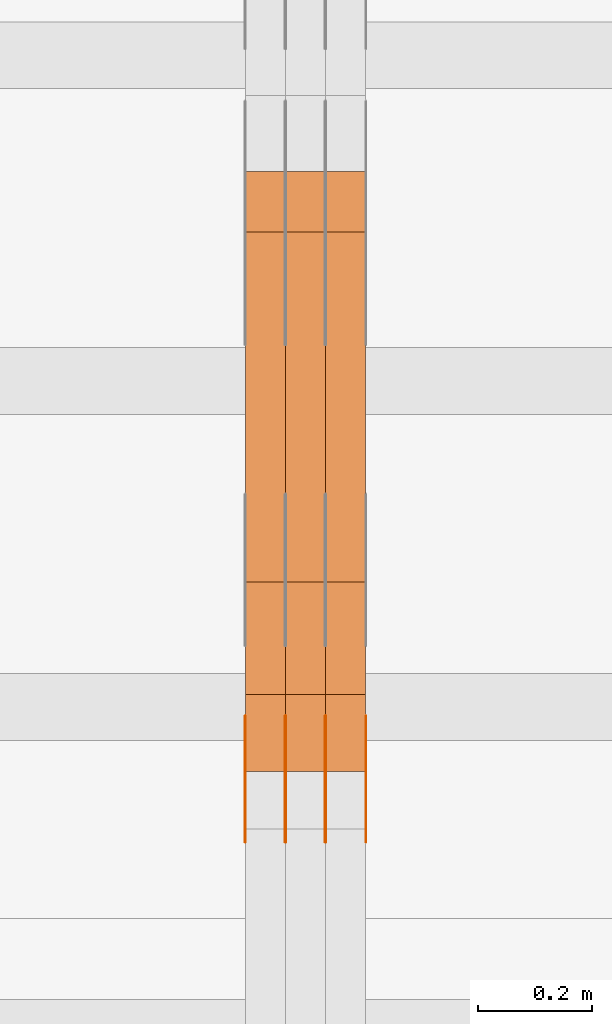
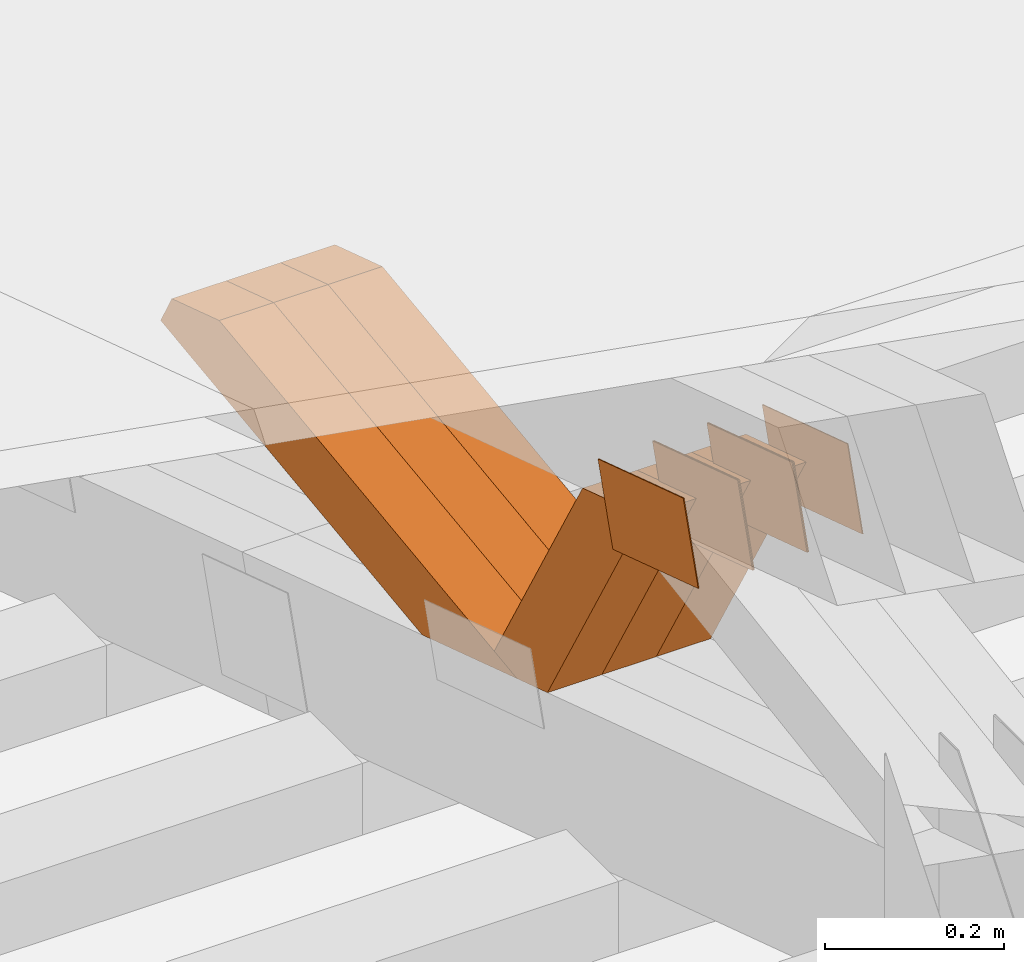
# One storey, part 107 of 385: 12 proxies.
"""IFC2X3 building model written with IfcOpenShell, lengths in millimetres."""

import ifcopenshell
import ifcopenshell.guid

model = None  # the IFC model being written
_history = None  # IfcOwnerHistory: only IFC2X3 demands one
_inside = {}  # id of a spatial element -> (the spatial element, [elements in it])
_under = {}  # id of a project, library or spatial element -> (it, [spatial elements below it])
_declared = {}  # id of a project -> (the project, [libraries it declares])
_typed = {}  # id of a type object -> (the type object, [elements of that type])
_made_of = {}  # id of a material, layer set ... -> (it, [elements and type objects made of it])


def new_model(schema):
    """Start an empty IFC model of exactly this schema.

    Asked for "IFC4X3", IfcOpenShell would pick the latest addendum, in which some entities
    have other attributes; the version numbers below select the first issue.
    IFC2X3 requires an IfcOwnerHistory on every rooted entity: one is made here for all.
    """
    global model, _history
    if schema == "IFC4X3":
        model = ifcopenshell.file(schema_version=(4, 3, 0, 0))
    else:
        model = ifcopenshell.file(schema=schema)
    _inside.clear()
    _under.clear()
    _declared.clear()
    _typed.clear()
    _made_of.clear()
    _history = None
    if model.schema == "IFC2X3":
        org = make("IfcOrganization", Name="unknown")
        user = make(
            "IfcPersonAndOrganization",
            ThePerson=make("IfcPerson", FamilyName="unknown"),
            TheOrganization=org,
        )
        app = make(
            "IfcApplication",
            ApplicationDeveloper=org,
            Version="unknown",
            ApplicationFullName="unknown",
            ApplicationIdentifier="unknown",
        )
        _history = make(
            "IfcOwnerHistory",
            OwningUser=user,
            OwningApplication=app,
            ChangeAction="ADDED",
            CreationDate=0,
        )
    return model


def make(cls, **values):
    """One entity of the class cls with the attributes given. An attribute that is None is left unset."""
    return model.create_entity(
        cls, **{name: value for name, value in values.items() if value is not None}
    )


def entity(cls, *values):
    """Any entity or typed value of the class cls, its attributes in the order of the schema. None: left unset."""
    e = model.create_entity(cls)
    for i, value in enumerate(values):
        if value is not None:
            e[i] = value
    return e


def rooted(cls, **values):
    """An entity with a GlobalId (a new one), such as an element, a storey or a relation."""
    return make(cls, GlobalId=ifcopenshell.guid.new(), OwnerHistory=_history, **values)


def si_unit(unit_type, name, prefix=None):
    """IfcSIUnit, for example si_unit("LENGTHUNIT", "METRE", prefix="MILLI")."""
    return make("IfcSIUnit", UnitType=unit_type, Prefix=prefix, Name=name)


def converted_unit(unit_type, name, factor, base, dimensions=None, offset=None):
    """IfcConversionBasedUnit, such as the inch: factor (a typed value) times the base unit."""
    return make(
        "IfcConversionBasedUnit"
        if offset is None
        else "IfcConversionBasedUnitWithOffset",
        ConversionOffset=offset,
        Dimensions=None
        if dimensions is None
        else entity("IfcDimensionalExponents", *dimensions),
        UnitType=unit_type,
        Name=name,
        ConversionFactor=make(
            "IfcMeasureWithUnit", ValueComponent=factor, UnitComponent=base
        ),
    )


def derived_unit(unit_type, elements):
    """IfcDerivedUnit: a product of units, each with its exponent."""
    return make(
        "IfcDerivedUnit",
        Elements=[
            make("IfcDerivedUnitElement", Unit=unit, Exponent=power)
            for unit, power in elements
        ],
        UnitType=unit_type,
    )


def assignment(units):
    """IfcUnitAssignment: the units of a project."""
    return None if units is None else make("IfcUnitAssignment", Units=units)


def point(xyz):
    """IfcCartesianPoint."""
    return None if xyz is None else make("IfcCartesianPoint", Coordinates=xyz)


def direction(xyz):
    """IfcDirection."""
    return None if xyz is None else make("IfcDirection", DirectionRatios=xyz)


def frame(location, z_axis=None, x_axis=None):
    """IfcAxis2Placement3D, a coordinate frame: its origin and axes. An axis left out is left unset."""
    return make(
        "IfcAxis2Placement3D",
        Location=point(location),
        Axis=direction(z_axis),
        RefDirection=direction(x_axis),
    )


def origin():
    """The frame at (0, 0, 0) with its axes left unset."""
    return frame((0.0, 0.0, 0.0))


def place(relative_to, where):
    """IfcLocalPlacement: puts the frame where relative to a parent placement (None: the world)."""
    return make(
        "IfcLocalPlacement", PlacementRelTo=relative_to, RelativePlacement=where
    )


def context(
    kind, dimensions, precision=None, world=None, true_north=None, identifier=None
):
    """IfcGeometricRepresentationContext, for example the 3D "Model" context."""
    return make(
        "IfcGeometricRepresentationContext",
        ContextIdentifier=identifier,
        ContextType=kind,
        CoordinateSpaceDimension=dimensions,
        Precision=precision,
        WorldCoordinateSystem=world,
        TrueNorth=true_north,
    )


def subcontext(parent, identifier, kind, view, scale=None):
    """IfcGeometricRepresentationSubContext, for example "Body" below "Model"."""
    return make(
        "IfcGeometricRepresentationSubContext",
        ContextIdentifier=identifier,
        ContextType=kind,
        ParentContext=parent,
        TargetScale=scale,
        TargetView=view,
    )


def project(units=None, contexts=None):
    """IfcProject with its units and contexts."""
    return rooted(
        "IfcProject",
        Name="project",
        RepresentationContexts=contexts,
        UnitsInContext=assignment(units),
    )


def spatial(cls, under=None, at=None, **own):
    """A site, building, storey or space (cls), placed at a placement, below another one or the project."""
    s = rooted(cls, ObjectPlacement=at, **own)
    if under is not None:
        _under.setdefault(under.id(), (under, []))[1].append(s)
    return s


def polyline(points):
    """IfcPolyline through the points."""
    return make("IfcPolyline", Points=[point(p) for p in points])


def outline(outer, holes=None, kind="AREA"):
    """IfcArbitraryClosedProfileDef: a profile drawn as a closed curve; with holes, ...WithVoids."""
    if holes is None:
        return make("IfcArbitraryClosedProfileDef", ProfileType=kind, OuterCurve=outer)
    return make(
        "IfcArbitraryProfileDefWithVoids",
        ProfileType=kind,
        OuterCurve=outer,
        InnerCurves=holes,
    )


def extrude(swept, where, along, depth):
    """IfcExtrudedAreaSolid: the profile swept, set in the frame where, extruded along a direction by depth."""
    return make(
        "IfcExtrudedAreaSolid",
        SweptArea=swept,
        Position=where,
        ExtrudedDirection=direction(along),
        Depth=depth,
    )


def shape(context_of_items, identifier, shape_type, items):
    """IfcShapeRepresentation: the items that make up one representation, for example the "Body"."""
    return make(
        "IfcShapeRepresentation",
        ContextOfItems=context_of_items,
        RepresentationIdentifier=identifier,
        RepresentationType=shape_type,
        Items=items,
    )


def source(mapping_origin, context_of_items, identifier, shape_type, items):
    """IfcRepresentationMap: a shape defined once, which mapped items show again and again."""
    return make(
        "IfcRepresentationMap",
        MappingOrigin=mapping_origin,
        MappedRepresentation=shape(context_of_items, identifier, shape_type, items),
    )


def transform(
    local_origin,
    x_axis=None,
    y_axis=None,
    z_axis=None,
    scale=None,
    scale2=None,
    scale3=None,
    uniform=True,
):
    """IfcCartesianTransformationOperator3D, or its non-uniform kind. x_axis, y_axis, z_axis: its Axis1, 2, 3."""
    if uniform:
        return make(
            "IfcCartesianTransformationOperator3D",
            Axis1=direction(x_axis),
            Axis2=direction(y_axis),
            LocalOrigin=point(local_origin),
            Scale=scale,
            Axis3=direction(z_axis),
        )
    return make(
        "IfcCartesianTransformationOperator3DnonUniform",
        Axis1=direction(x_axis),
        Axis2=direction(y_axis),
        LocalOrigin=point(local_origin),
        Scale=scale,
        Axis3=direction(z_axis),
        Scale2=scale2,
        Scale3=scale3,
    )


def mapped(mapping_source, mapping_target):
    """IfcMappedItem: shows the shape of a source again, moved by a transform."""
    return make(
        "IfcMappedItem", MappingSource=mapping_source, MappingTarget=mapping_target
    )


def material(Name=None, Category=None):
    """IfcMaterial."""
    return make("IfcMaterial", Name=Name, Category=Category)


def made_of(thing, what):
    """Note that an element or type object is made of a material, layer set ...; save() writes the relation."""
    if what is not None:
        _made_of.setdefault(what.id(), (what, []))[1].append(thing)
    return thing


def type_object(cls, material=None, **own):
    """A type object (cls), such as IfcWallType, which elements share."""
    return made_of(rooted(cls, **own), material)


def type_shapes(of_type, sources):
    """Give a type object the sources (RepresentationMaps) that its elements show as mapped items."""
    of_type.RepresentationMaps = sources


def element(
    cls,
    number,
    at=None,
    inside=None,
    cuts=None,
    type_object=None,
    material=None,
    context=None,
    identifier="Body",
    shape_type=None,
    held_by="IfcProductDefinitionShape",
    body=None,
    shapes=None,
    **own,
):
    """One element of the class cls, such as IfcWall. Its Tag is "e" and its number.

    at: its placement. inside: the storey or other place that contains it. cuts: it is an
    opening in that element (IfcRelVoidsElement). A single representation is given by context,
    identifier, shape_type and body (its items); several are given by shapes. held_by: the class
    of the entity that holds the representations. save() writes the other relations.
    """
    e = rooted(cls, Tag="e%d" % number, ObjectPlacement=at, **own)
    if body is not None:
        shapes = [shape(context, identifier, shape_type, body)]
    if shapes is not None:
        e.Representation = make(held_by, Representations=shapes)
    if inside is not None:
        _inside.setdefault(inside.id(), (inside, []))[1].append(e)
    if cuts is not None:
        rooted(
            "IfcRelVoidsElement", RelatingBuildingElement=cuts, RelatedOpeningElement=e
        )
    if type_object is not None:
        _typed.setdefault(type_object.id(), (type_object, []))[1].append(e)
    return made_of(e, material)


def aggregate(whole, parts):
    """IfcRelAggregates: a whole, such as a stair, and the parts it consists of."""
    return rooted("IfcRelAggregates", RelatingObject=whole, RelatedObjects=parts)


def save(model, path):
    """Write the relations noted so far, then the file.

    IfcRelAggregates (storeys below a building ...), IfcRelContainedInSpatialStructure (elements
    in a storey), IfcRelDefinesByType, IfcRelAssociatesMaterial and IfcRelDeclares: one each for
    every whole, place, type object, material and project.
    """
    for whole, parts in _under.values():
        aggregate(whole, parts)
    for where, things in _inside.values():
        rooted(
            "IfcRelContainedInSpatialStructure",
            RelatedElements=things,
            RelatingStructure=where,
        )
    for kind, things in _typed.values():
        rooted("IfcRelDefinesByType", RelatedObjects=things, RelatingType=kind)
    for what, things in _made_of.values():
        rooted("IfcRelAssociatesMaterial", RelatedObjects=things, RelatingMaterial=what)
    for by, libraries in _declared.values():
        rooted("IfcRelDeclares", RelatingContext=by, RelatedDefinitions=libraries)
    model.write(path)


model = new_model("IFC2X3")

# Units and contexts
model_context = context("Model", 3, precision=0.01, world=origin(), true_north=direction((6.12303176911189e-17, 1.0)))
body_context = subcontext(model_context, "Body", "Model", "MODEL_VIEW")
ifc_project = project(units=[si_unit("LENGTHUNIT", "METRE", prefix="MILLI"), si_unit("AREAUNIT", "SQUARE_METRE"), si_unit("VOLUMEUNIT", "CUBIC_METRE"), converted_unit("PLANEANGLEUNIT", "DEGREE", entity("IfcRatioMeasure", 0.0174532925199433), si_unit("PLANEANGLEUNIT", "RADIAN"), dimensions=[0, 0, 0, 0, 0, 0, 0]), si_unit("MASSUNIT", "GRAM", prefix="KILO"), derived_unit("MASSDENSITYUNIT", [(si_unit("MASSUNIT", "GRAM", prefix="KILO"), 1), (si_unit("LENGTHUNIT", "METRE"), -3)]), si_unit("TIMEUNIT", "SECOND"), si_unit("FREQUENCYUNIT", "HERTZ"), si_unit("THERMODYNAMICTEMPERATUREUNIT", "DEGREE_CELSIUS"), derived_unit("THERMALTRANSMITTANCEUNIT", [(si_unit("MASSUNIT", "GRAM", prefix="KILO"), 1), (si_unit("THERMODYNAMICTEMPERATUREUNIT", "KELVIN"), -1), (si_unit("TIMEUNIT", "SECOND"), -3)]), derived_unit("VOLUMETRICFLOWRATEUNIT", [(si_unit("LENGTHUNIT", "METRE"), 3), (si_unit("TIMEUNIT", "SECOND"), -1)]), si_unit("ELECTRICCURRENTUNIT", "AMPERE"), si_unit("ELECTRICVOLTAGEUNIT", "VOLT"), si_unit("POWERUNIT", "WATT"), si_unit("FORCEUNIT", "NEWTON", prefix="KILO"), si_unit("ILLUMINANCEUNIT", "LUX"), si_unit("LUMINOUSFLUXUNIT", "LUMEN"), si_unit("LUMINOUSINTENSITYUNIT", "CANDELA"), derived_unit("USERDEFINED", [(si_unit("MASSUNIT", "GRAM", prefix="KILO"), -1), (si_unit("LENGTHUNIT", "METRE"), -2), (si_unit("TIMEUNIT", "SECOND"), 3), (si_unit("LUMINOUSFLUXUNIT", "LUMEN"), 1)]), derived_unit("LINEARVELOCITYUNIT", [(si_unit("LENGTHUNIT", "METRE"), 1), (si_unit("TIMEUNIT", "SECOND"), -1)]), si_unit("PRESSUREUNIT", "PASCAL"), derived_unit("USERDEFINED", [(si_unit("LENGTHUNIT", "METRE"), -2), (si_unit("MASSUNIT", "GRAM", prefix="KILO"), 1), (si_unit("TIMEUNIT", "SECOND"), -2)])], contexts=[model_context])

# Site, building, storey
site_placement = place(None, origin())
site = spatial("IfcSite", under=ifc_project, at=site_placement, CompositionType="ELEMENT")
building_placement = place(site_placement, origin())
building = spatial("IfcBuilding", under=site, at=building_placement, CompositionType="ELEMENT")
storey_placement = place(building_placement, origin())
storey = spatial("IfcBuildingStorey", under=building, at=storey_placement, Name="Default", CompositionType="ELEMENT", Elevation=0.0)

# Proxies
ifc_material_1 = material(Name="IfcSurfaceStyle #198538")
building_element_proxy_type_1 = type_object("IfcBuildingElementProxyType", PredefinedType="NOTDEFINED", material=ifc_material_1)
shared_shape_1 = source(origin(), body_context, "Body", "SweptSolid", [
    extrude(outline(polyline([(-99.9999427841299, -54.0000599375792), (99.9996549037756, -54.0000599375792), (100.000407167194, 54.0000599375792), (-100.00011928684, 54.0000599375792), (-99.9999427841299, -54.0000599375792)])), frame((100.000407167194, 54.0000599375792, 0.0), z_axis=(0.0, 0.0, 1.0), x_axis=(-1.0, 0.0, 0.0)), (0.0, 0.0, 1.0), 1.3),
])
type_shapes(building_element_proxy_type_1, [shared_shape_1])
proxy_1_placement = place(building_placement, frame((15386.3, 18065.0682492591, 3072.55239547302), z_axis=(-1.0, 0.0, 0.0), x_axis=(0.0, -0.951056516295154, 0.309016994374948)))
element("IfcBuildingElementProxy", 1, at=proxy_1_placement, inside=storey, type_object=building_element_proxy_type_1, material=ifc_material_1, context=body_context, shape_type="MappedRepresentation", body=[
    mapped(shared_shape_1, transform((0.0, 0.0, 0.0), scale=1.0)),
])
ifc_material_2 = material(Name="IfcSurfaceStyle #198481")
building_element_proxy_type_2 = type_object("IfcBuildingElementProxyType", PredefinedType="NOTDEFINED", material=ifc_material_2)
shared_shape_2 = source(origin(), body_context, "Body", "SweptSolid", [
    extrude(outline(polyline([(-99.9999427841299, -54.0000599375792), (99.9996549037756, -54.0000599375792), (100.000407167194, 54.0000599375792), (-100.00011928684, 54.0000599375792), (-99.9999427841299, -54.0000599375792)])), frame((100.000407167194, 54.0000599375792, 0.0), z_axis=(0.0, 0.0, 1.0), x_axis=(-1.0, 0.0, 0.0)), (0.0, 0.0, 1.0), 1.3),
])
type_shapes(building_element_proxy_type_2, [shared_shape_2])
proxy_2_placement = place(building_placement, frame((15315.0, 18065.0682492591, 3072.55239547302), z_axis=(-1.0, 0.0, 0.0), x_axis=(0.0, -0.951056516295154, 0.309016994374948)))
element("IfcBuildingElementProxy", 2, at=proxy_2_placement, inside=storey, type_object=building_element_proxy_type_2, material=ifc_material_2, context=body_context, shape_type="MappedRepresentation", body=[
    mapped(shared_shape_2, transform((0.0, 0.0, 0.0), scale=1.0)),
])
ifc_material_3 = material(Name="IfcSurfaceStyle #198424")
building_element_proxy_type_3 = type_object("IfcBuildingElementProxyType", PredefinedType="NOTDEFINED", material=ifc_material_3)
shared_shape_3 = source(origin(), body_context, "Body", "SweptSolid", [
    extrude(outline(polyline([(-99.9999427841299, -54.0000599375792), (99.9996549037756, -54.0000599375792), (100.000407167194, 54.0000599375792), (-100.00011928684, 54.0000599375792), (-99.9999427841299, -54.0000599375792)])), frame((100.000407167194, 54.0000599375792, 0.0), z_axis=(0.0, 0.0, 1.0), x_axis=(-1.0, 0.0, 0.0)), (0.0, 0.0, 1.0), 1.3),
])
type_shapes(building_element_proxy_type_3, [shared_shape_3])
proxy_3_placement = place(building_placement, frame((15316.3, 18065.0682492591, 3072.55239547302), z_axis=(-1.0, 0.0, 0.0), x_axis=(0.0, -0.951056516295154, 0.309016994374948)))
element("IfcBuildingElementProxy", 3, at=proxy_3_placement, inside=storey, type_object=building_element_proxy_type_3, material=ifc_material_3, context=body_context, shape_type="MappedRepresentation", body=[
    mapped(shared_shape_3, transform((0.0, 0.0, 0.0), scale=1.0)),
])
ifc_material_4 = material(Name="IfcSurfaceStyle #198367")
building_element_proxy_type_4 = type_object("IfcBuildingElementProxyType", PredefinedType="NOTDEFINED", material=ifc_material_4)
shared_shape_4 = source(origin(), body_context, "Body", "SweptSolid", [
    extrude(outline(polyline([(-99.9999427841299, -54.0000599375792), (99.9996549037756, -54.0000599375792), (100.000407167194, 54.0000599375792), (-100.00011928684, 54.0000599375792), (-99.9999427841299, -54.0000599375792)])), frame((100.000407167194, 54.0000599375792, 0.0), z_axis=(0.0, 0.0, 1.0), x_axis=(-1.0, 0.0, 0.0)), (0.0, 0.0, 1.0), 1.29999999999998),
])
type_shapes(building_element_proxy_type_4, [shared_shape_4])
proxy_4_placement = place(building_placement, frame((15245.0, 18065.0682492591, 3072.55239547302), z_axis=(-1.0, 0.0, 0.0), x_axis=(0.0, -0.951056516295154, 0.309016994374948)))
element("IfcBuildingElementProxy", 4, at=proxy_4_placement, inside=storey, type_object=building_element_proxy_type_4, material=ifc_material_4, context=body_context, shape_type="MappedRepresentation", body=[
    mapped(shared_shape_4, transform((0.0, 0.0, 0.0), scale=1.0)),
])
ifc_material_5 = material(Name="IfcSurfaceStyle #198310")
building_element_proxy_type_5 = type_object("IfcBuildingElementProxyType", PredefinedType="NOTDEFINED", material=ifc_material_5)
shared_shape_5 = source(origin(), body_context, "Body", "SweptSolid", [
    extrude(outline(polyline([(-99.9999427841299, -54.0000599375792), (99.9996549037756, -54.0000599375792), (100.000407167194, 54.0000599375792), (-100.00011928684, 54.0000599375792), (-99.9999427841299, -54.0000599375792)])), frame((100.000407167194, 54.0000599375792, 0.0), z_axis=(0.0, 0.0, 1.0), x_axis=(-1.0, 0.0, 0.0)), (0.0, 0.0, 1.0), 1.29999999999998),
])
type_shapes(building_element_proxy_type_5, [shared_shape_5])
proxy_5_placement = place(building_placement, frame((15246.3, 18065.0682492591, 3072.55239547302), z_axis=(-1.0, 0.0, 0.0), x_axis=(0.0, -0.951056516295154, 0.309016994374948)))
element("IfcBuildingElementProxy", 5, at=proxy_5_placement, inside=storey, type_object=building_element_proxy_type_5, material=ifc_material_5, context=body_context, shape_type="MappedRepresentation", body=[
    mapped(shared_shape_5, transform((0.0, 0.0, 0.0), scale=1.0)),
])
ifc_material_6 = material(Name="IfcSurfaceStyle #198253")
building_element_proxy_type_6 = type_object("IfcBuildingElementProxyType", PredefinedType="NOTDEFINED", material=ifc_material_6)
shared_shape_6 = source(origin(), body_context, "Body", "SweptSolid", [
    extrude(outline(polyline([(-99.9999427841299, -54.0000599375792), (99.9996549037756, -54.0000599375792), (100.000407167194, 54.0000599375792), (-100.00011928684, 54.0000599375792), (-99.9999427841299, -54.0000599375792)])), frame((100.000407167194, 54.0000599375792, 0.0), z_axis=(0.0, 0.0, 1.0), x_axis=(-1.0, 0.0, 0.0)), (0.0, 0.0, 1.0), 1.29999999999999),
])
type_shapes(building_element_proxy_type_6, [shared_shape_6])
proxy_6_placement = place(building_placement, frame((15175.0, 18065.0682492591, 3072.55239547302), z_axis=(-1.0, 0.0, 0.0), x_axis=(0.0, -0.951056516295154, 0.309016994374948)))
element("IfcBuildingElementProxy", 6, at=proxy_6_placement, inside=storey, type_object=building_element_proxy_type_6, material=ifc_material_6, context=body_context, shape_type="MappedRepresentation", body=[
    mapped(shared_shape_6, transform((0.0, 0.0, 0.0), scale=1.0)),
])
ifc_material_7 = material(Name="IfcSurfaceStyle #188386")
building_element_proxy_type_7 = type_object("IfcBuildingElementProxyType", Name="T1-W35 188384", PredefinedType="NOTDEFINED", material=ifc_material_7)
shared_shape_7 = source(origin(), body_context, "Body", "SweptSolid", [
    extrude(outline(polyline([(-196.877231354918, -47.499850828051), (197.289756738813, -47.499850828051), (177.380838136073, -0.000131002767018074), (124.615181369032, 47.4999163294346), (-302.408544889, 47.4999163294346), (-196.877231354918, -47.499850828051)])), frame((197.289756738813, 47.5002438363521, 0.0), z_axis=(0.0, 0.0, 1.0), x_axis=(-1.0, 0.0, 0.0)), (0.0, 0.0, 1.0), 70.0),
])
type_shapes(building_element_proxy_type_7, [shared_shape_7])
proxy_7_placement = place(building_placement, frame((15385.0, 18249.5528960018, 2724.16980022534), z_axis=(-1.0, 0.0, 0.0), x_axis=(0.0, -0.5, 0.866025403784439)))
element("IfcBuildingElementProxy", 7, at=proxy_7_placement, inside=storey, type_object=building_element_proxy_type_7, material=ifc_material_7, Name="T1-W35", context=body_context, shape_type="MappedRepresentation", body=[
    mapped(shared_shape_7, transform((0.0, 0.0, 0.0), scale=1.0)),
])
ifc_material_8 = material(Name="IfcSurfaceStyle #188320")
building_element_proxy_type_8 = type_object("IfcBuildingElementProxyType", Name="T1-W35 188318", PredefinedType="NOTDEFINED", material=ifc_material_8)
shared_shape_8 = source(origin(), body_context, "Body", "SweptSolid", [
    extrude(outline(polyline([(-196.877231354918, -47.499850828051), (197.289756738813, -47.499850828051), (177.380838136073, -0.000131002767018074), (124.615181369032, 47.4999163294346), (-302.408544889, 47.4999163294346), (-196.877231354918, -47.499850828051)])), frame((197.289756738813, 47.5002438363521, 0.0), z_axis=(0.0, 0.0, 1.0), x_axis=(-1.0, 0.0, 0.0)), (0.0, 0.0, 1.0), 70.0),
])
type_shapes(building_element_proxy_type_8, [shared_shape_8])
proxy_8_placement = place(building_placement, frame((15315.0, 18249.5528960018, 2724.16980022534), z_axis=(-1.0, 0.0, 0.0), x_axis=(0.0, -0.5, 0.866025403784439)))
element("IfcBuildingElementProxy", 8, at=proxy_8_placement, inside=storey, type_object=building_element_proxy_type_8, material=ifc_material_8, Name="T1-W35", context=body_context, shape_type="MappedRepresentation", body=[
    mapped(shared_shape_8, transform((0.0, 0.0, 0.0), scale=1.0)),
])
ifc_material_9 = material(Name="IfcSurfaceStyle #188254")
building_element_proxy_type_9 = type_object("IfcBuildingElementProxyType", Name="T1-W35 188252", PredefinedType="NOTDEFINED", material=ifc_material_9)
shared_shape_9 = source(origin(), body_context, "Body", "SweptSolid", [
    extrude(outline(polyline([(-196.877231354918, -47.499850828051), (197.289756738813, -47.499850828051), (177.380838136073, -0.000131002767018074), (124.615181369032, 47.4999163294346), (-302.408544889, 47.4999163294346), (-196.877231354918, -47.499850828051)])), frame((197.289756738813, 47.5002438363521, 0.0), z_axis=(0.0, 0.0, 1.0), x_axis=(-1.0, 0.0, 0.0)), (0.0, 0.0, 1.0), 70.0),
])
type_shapes(building_element_proxy_type_9, [shared_shape_9])
proxy_9_placement = place(building_placement, frame((15245.0, 18249.5528960018, 2724.16980022534), z_axis=(-1.0, 0.0, 0.0), x_axis=(0.0, -0.5, 0.866025403784439)))
element("IfcBuildingElementProxy", 9, at=proxy_9_placement, inside=storey, type_object=building_element_proxy_type_9, material=ifc_material_9, Name="T1-W35", context=body_context, shape_type="MappedRepresentation", body=[
    mapped(shared_shape_9, transform((0.0, 0.0, 0.0), scale=1.0)),
])
ifc_material_10 = material(Name="IfcSurfaceStyle #187990")
building_element_proxy_type_10 = type_object("IfcBuildingElementProxyType", Name="T1-W6 187988", PredefinedType="NOTDEFINED", material=ifc_material_10)
shared_shape_10 = source(origin(), body_context, "Body", "SweptSolid", [
    extrude(outline(polyline([(-485.945461934772, -47.500204767976), (183.41906495488, -47.500204767976), (284.061400026172, 0.000179660053988773), (303.127757064591, 47.500114937949), (-284.66276011087, 47.500114937949), (-485.945461934772, -47.500204767976)])), frame((303.127970456024, 47.5001450766485, 0.0), z_axis=(0.0, 0.0, 1.0), x_axis=(-1.0, 0.0, 0.0)), (0.0, 0.0, 1.0), 70.0),
])
type_shapes(building_element_proxy_type_10, [shared_shape_10])
proxy_10_placement = place(building_placement, frame((15385.0, 19075.4826373647, 2770.72729201433), z_axis=(-1.0, 0.0, 0.0), x_axis=(0.0, -0.991969529622927, -0.126477082112413)))
element("IfcBuildingElementProxy", 10, at=proxy_10_placement, inside=storey, type_object=building_element_proxy_type_10, material=ifc_material_10, Name="T1-W6", context=body_context, shape_type="MappedRepresentation", body=[
    mapped(shared_shape_10, transform((0.0, 0.0, 0.0), scale=1.0)),
])
ifc_material_11 = material(Name="IfcSurfaceStyle #187924")
building_element_proxy_type_11 = type_object("IfcBuildingElementProxyType", Name="T1-W6 187922", PredefinedType="NOTDEFINED", material=ifc_material_11)
shared_shape_11 = source(origin(), body_context, "Body", "SweptSolid", [
    extrude(outline(polyline([(-485.945461934772, -47.500204767976), (183.41906495488, -47.500204767976), (284.061400026172, 0.000179660053988773), (303.127757064591, 47.500114937949), (-284.66276011087, 47.500114937949), (-485.945461934772, -47.500204767976)])), frame((303.127970456024, 47.5001450766485, 0.0), z_axis=(0.0, 0.0, 1.0), x_axis=(-1.0, 0.0, 0.0)), (0.0, 0.0, 1.0), 70.0),
])
type_shapes(building_element_proxy_type_11, [shared_shape_11])
proxy_11_placement = place(building_placement, frame((15315.0, 19075.4826373647, 2770.72729201433), z_axis=(-1.0, 0.0, 0.0), x_axis=(0.0, -0.991969529622927, -0.126477082112413)))
element("IfcBuildingElementProxy", 11, at=proxy_11_placement, inside=storey, type_object=building_element_proxy_type_11, material=ifc_material_11, Name="T1-W6", context=body_context, shape_type="MappedRepresentation", body=[
    mapped(shared_shape_11, transform((0.0, 0.0, 0.0), scale=1.0)),
])
ifc_material_12 = material(Name="IfcSurfaceStyle #187858")
building_element_proxy_type_12 = type_object("IfcBuildingElementProxyType", Name="T1-W6 187856", PredefinedType="NOTDEFINED", material=ifc_material_12)
shared_shape_12 = source(origin(), body_context, "Body", "SweptSolid", [
    extrude(outline(polyline([(-485.945461934772, -47.500204767976), (183.41906495488, -47.500204767976), (284.061400026172, 0.000179660053988773), (303.127757064591, 47.500114937949), (-284.66276011087, 47.500114937949), (-485.945461934772, -47.500204767976)])), frame((303.127970456024, 47.5001450766485, 0.0), z_axis=(0.0, 0.0, 1.0), x_axis=(-1.0, 0.0, 0.0)), (0.0, 0.0, 1.0), 70.0),
])
type_shapes(building_element_proxy_type_12, [shared_shape_12])
proxy_12_placement = place(building_placement, frame((15245.0, 19075.4826373647, 2770.72729201433), z_axis=(-1.0, 0.0, 0.0), x_axis=(0.0, -0.991969529622927, -0.126477082112413)))
element("IfcBuildingElementProxy", 12, at=proxy_12_placement, inside=storey, type_object=building_element_proxy_type_12, material=ifc_material_12, Name="T1-W6", context=body_context, shape_type="MappedRepresentation", body=[
    mapped(shared_shape_12, transform((0.0, 0.0, 0.0), scale=1.0)),
])

save(model, "model.ifc")
